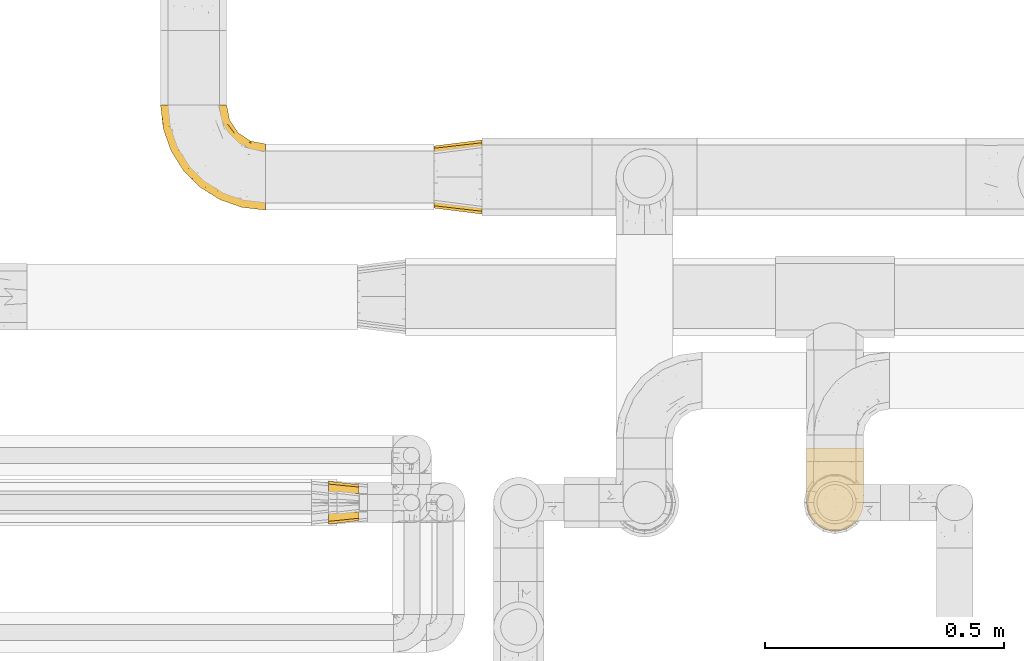
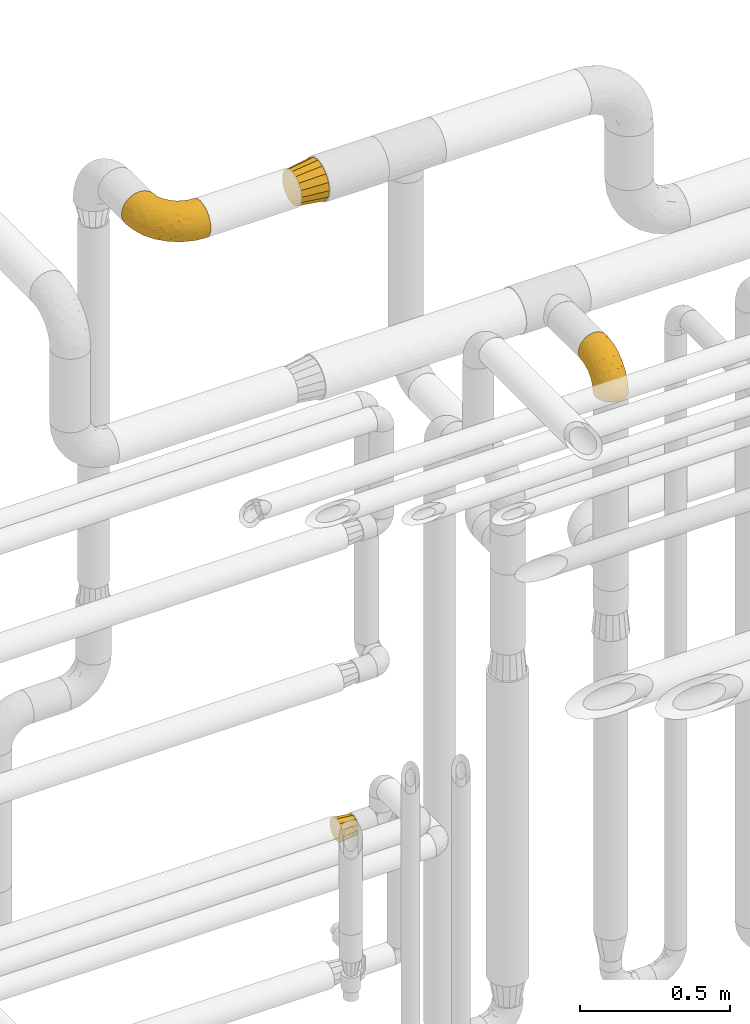
# One storey, part 459 of 827: 4 coverings.
"""IFC2X3 building model written with IfcOpenShell, lengths in millimetres."""

from ifc_helpers import new_model, entity, si_unit, converted_unit, derived_unit, direction, frame, origin, place, context, subcontext, project, spatial, faceted_brep, element, save


model = new_model("IFC2X3")

# Units and contexts
model_context = context("Model", 3, precision=0.01, world=origin(), true_north=direction((6.12303176911189e-17, 1.0)))
body_context = subcontext(model_context, "Body", "Model", "MODEL_VIEW")
ifc_project = project(units=[si_unit("LENGTHUNIT", "METRE", prefix="MILLI"), si_unit("AREAUNIT", "SQUARE_METRE"), si_unit("VOLUMEUNIT", "CUBIC_METRE"), converted_unit("PLANEANGLEUNIT", "DEGREE", entity("IfcRatioMeasure", 0.0174532925199433), si_unit("PLANEANGLEUNIT", "RADIAN"), dimensions=[0, 0, 0, 0, 0, 0, 0]), si_unit("MASSUNIT", "GRAM", prefix="KILO"), derived_unit("MASSDENSITYUNIT", [(si_unit("MASSUNIT", "GRAM", prefix="KILO"), 1), (si_unit("LENGTHUNIT", "METRE"), -3)]), derived_unit("MOMENTOFINERTIAUNIT", [(si_unit("LENGTHUNIT", "METRE"), 4)]), si_unit("TIMEUNIT", "SECOND"), si_unit("FREQUENCYUNIT", "HERTZ"), si_unit("THERMODYNAMICTEMPERATUREUNIT", "DEGREE_CELSIUS"), derived_unit("THERMALTRANSMITTANCEUNIT", [(si_unit("MASSUNIT", "GRAM", prefix="KILO"), 1), (si_unit("THERMODYNAMICTEMPERATUREUNIT", "KELVIN"), -1), (si_unit("TIMEUNIT", "SECOND"), -3)]), derived_unit("VOLUMETRICFLOWRATEUNIT", [(si_unit("LENGTHUNIT", "METRE"), 3), (si_unit("TIMEUNIT", "SECOND"), -1)]), derived_unit("MASSFLOWRATEUNIT", [(si_unit("MASSUNIT", "GRAM", prefix="KILO"), 1), (si_unit("TIMEUNIT", "SECOND"), -1)]), derived_unit("ROTATIONALFREQUENCYUNIT", [(si_unit("TIMEUNIT", "SECOND"), -1)]), si_unit("ELECTRICCURRENTUNIT", "AMPERE"), si_unit("ELECTRICVOLTAGEUNIT", "VOLT"), si_unit("POWERUNIT", "WATT"), si_unit("FORCEUNIT", "NEWTON", prefix="KILO"), si_unit("ILLUMINANCEUNIT", "LUX"), si_unit("LUMINOUSFLUXUNIT", "LUMEN"), si_unit("LUMINOUSINTENSITYUNIT", "CANDELA"), derived_unit("USERDEFINED", [(si_unit("MASSUNIT", "GRAM", prefix="KILO"), -1), (si_unit("LENGTHUNIT", "METRE"), -2), (si_unit("TIMEUNIT", "SECOND"), 3), (si_unit("LUMINOUSFLUXUNIT", "LUMEN"), 1)]), derived_unit("LINEARVELOCITYUNIT", [(si_unit("LENGTHUNIT", "METRE"), 1), (si_unit("TIMEUNIT", "SECOND"), -1)]), si_unit("PRESSUREUNIT", "PASCAL"), derived_unit("USERDEFINED", [(si_unit("LENGTHUNIT", "METRE"), -2), (si_unit("MASSUNIT", "GRAM", prefix="KILO"), 1), (si_unit("TIMEUNIT", "SECOND"), -2)]), derived_unit("LINEARFORCEUNIT", [(si_unit("MASSUNIT", "GRAM", prefix="KILO"), 1), (si_unit("LENGTHUNIT", "METRE"), 1), (si_unit("TIMEUNIT", "SECOND"), -2), (si_unit("LENGTHUNIT", "METRE"), -1)]), derived_unit("PLANARFORCEUNIT", [(si_unit("MASSUNIT", "GRAM", prefix="KILO"), 1), (si_unit("LENGTHUNIT", "METRE"), 1), (si_unit("TIMEUNIT", "SECOND"), -2), (si_unit("LENGTHUNIT", "METRE"), -2)])], contexts=[model_context])

# Site, building, storey
site_placement = place(None, origin())
site = spatial("IfcSite", under=ifc_project, at=site_placement, CompositionType="ELEMENT")
building_placement = place(site_placement, origin())
building = spatial("IfcBuilding", under=site, at=building_placement, CompositionType="ELEMENT")
storey_placement = place(building_placement, frame((0.0, 0.0, 28200.0)))
storey = spatial("IfcBuildingStorey", under=building, at=storey_placement, Name="08", CompositionType="ELEMENT", Elevation=28200.0)

# Coverings
covering_1_placement = place(storey_placement, frame((57386.84, 17438.95, 2784.4)))
element("IfcCovering", 1, at=covering_1_placement, inside=storey, Name=":ADSK_", ObjectType=":ADSK_", PredefinedType="INSULATION", context=body_context, shape_type="Brep", body=[
    faceted_brep([(119.0, 47.81, 1.6), (114.61, 35.25, 1.6), (107.52, 23.97, 1.6), (98.11, 14.56, 1.6), (86.83, 7.48, 1.6), (74.26, 3.08, 1.6), (61.05, 1.6, 1.6), (47.81, 3.09, 1.6), (35.25, 7.48, 1.6), (23.97, 14.57, 1.6), (14.56, 23.99, 1.6), (7.48, 35.26, 1.6), (3.08, 47.83, 1.6), (1.6, 61.05, 1.6), (3.09, 74.28, 1.6), (7.48, 86.84, 1.6), (14.57, 98.12, 1.6), (23.99, 107.53, 1.6), (35.26, 114.61, 1.6), (47.83, 119.01, 1.6), (61.05, 120.5, 1.6), (74.28, 119.0, 1.6), (86.84, 114.61, 1.6), (98.12, 107.52, 1.6), (107.53, 98.11, 1.6), (114.61, 86.83, 1.6), (119.01, 74.26, 1.6), (120.5, 61.05, 1.6), (45.66, 175.05, 58.17), (31.32, 175.05, 64.11), (19.01, 175.05, 73.56), (9.56, 175.05, 85.87), (3.62, 175.05, 100.21), (1.6, 175.05, 115.6), (3.62, 175.05, 130.98), (9.56, 175.05, 145.32), (19.01, 175.05, 157.63), (31.32, 175.05, 167.08), (45.66, 175.05, 173.02), (61.05, 175.05, 175.05), (76.43, 175.05, 173.02), (90.77, 175.05, 167.08), (103.08, 175.05, 157.63), (112.53, 175.05, 145.32), (118.47, 175.05, 130.98), (120.5, 175.05, 115.6), (118.47, 175.05, 100.21), (112.53, 175.05, 85.87), (103.08, 175.05, 73.56), (90.77, 175.05, 64.11), (76.43, 175.05, 58.17), (61.05, 175.05, 56.15), (95.74, 144.29, 160.93), (82.17, 133.4, 165.97), (93.88, 108.85, 151.16), (71.8, 137.58, 169.95), (61.05, 130.15, 169.14), (109.14, 33.43, 47.74), (108.65, 48.64, 81.62), (100.7, 32.13, 69.65), (79.94, 71.77, 137.09), (61.05, 88.32, 151.81), (61.05, 52.4, 124.24), (115.7, 105.93, 120.32), (112.92, 128.22, 136.76), (110.7, 102.42, 129.05), (117.93, 138.98, 127.83), (119.47, 114.96, 111.19), (89.21, 25.03, 73.49), (91.01, 14.44, 40.92), (83.0, 103.12, 154.8), (71.74, 109.71, 161.22), (106.1, 133.1, 148.51), (61.05, 7.51, 46.49), (79.17, 9.66, 43.55), (76.32, 38.78, 105.65), (73.8, 19.81, 75.81), (112.99, 73.56, 102.22), (104.29, 65.59, 111.05), (119.46, 53.66, 31.64), (119.47, 65.45, 61.68), (115.7, 56.32, 70.72), (120.5, 108.04, 93.82), (120.5, 123.93, 101.92), (120.5, 139.82, 110.02), (61.05, 24.83, 88.32), (115.97, 42.35, 34.61), (101.43, 20.84, 34.27), (94.14, 74.42, 130.32), (94.58, 46.21, 101.6), (104.07, 96.34, 135.16), (118.63, 83.99, 92.65), (120.5, 82.82, 68.6), (120.5, 95.43, 81.21), (120.5, 63.36, 16.21), (120.5, 66.62, 36.82), (120.5, 74.72, 52.71), (120.5, 160.43, 113.28), (117.67, 91.97, 49.51), (114.99, 88.98, 24.29), (109.18, 102.6, 33.37), (118.26, 155.55, 97.47), (117.87, 141.61, 92.13), (111.2, 123.71, 65.64), (103.41, 136.88, 63.0), (108.57, 141.73, 72.44), (112.76, 108.95, 54.52), (75.65, 132.33, 38.38), (89.98, 131.77, 46.09), (85.51, 122.46, 30.11), (61.05, 124.65, 22.47), (73.87, 123.29, 22.86), (111.26, 158.35, 82.06), (101.69, 153.2, 68.74), (88.74, 147.72, 56.57), (86.0, 162.85, 60.39), (74.52, 158.54, 55.21), (70.92, 144.02, 47.46), (61.05, 154.17, 51.99), (118.96, 76.05, 19.27), (119.01, 98.34, 66.98), (117.67, 113.97, 75.5), (82.93, 117.88, 15.03), (96.71, 111.71, 21.65), (96.25, 120.52, 38.96), (106.01, 101.36, 16.17), (119.26, 79.3, 36.61), (105.56, 112.64, 42.47), (61.05, 136.47, 40.17), (114.42, 138.23, 81.33), (119.14, 124.93, 89.72), (102.94, 123.97, 52.09), (18.7, 136.9, 62.98), (19.16, 123.98, 52.08), (10.9, 123.74, 65.65), (5.81, 148.89, 89.82), (2.95, 124.93, 89.72), (2.72, 138.07, 97.2), (46.46, 132.31, 38.35), (9.34, 108.96, 54.51), (1.6, 82.82, 68.6), (1.6, 95.43, 81.21), (3.08, 98.34, 66.99), (47.58, 158.54, 55.21), (7.11, 88.99, 24.29), (36.09, 162.86, 60.39), (16.09, 101.37, 16.17), (25.4, 111.72, 21.63), (3.83, 155.55, 97.47), (1.6, 160.43, 113.28), (4.42, 113.97, 75.5), (20.4, 153.21, 68.74), (51.15, 144.01, 47.46), (10.83, 158.35, 82.06), (16.53, 112.65, 42.47), (25.84, 120.51, 38.93), (48.24, 123.29, 22.84), (1.6, 66.62, 36.82), (1.6, 74.72, 52.71), (2.83, 79.32, 36.62), (1.6, 63.36, 16.21), (36.6, 122.45, 30.08), (39.17, 117.88, 15.02), (32.11, 131.76, 46.08), (33.35, 147.73, 56.57), (1.6, 123.93, 101.92), (4.42, 91.99, 49.52), (12.92, 102.61, 33.36), (3.14, 76.07, 19.28), (13.52, 141.72, 72.43), (1.6, 108.04, 93.82), (1.6, 139.82, 110.02), (7.67, 138.23, 81.33), (28.21, 108.85, 151.16), (26.35, 144.29, 160.93), (15.99, 133.1, 148.51), (9.17, 128.22, 136.76), (50.29, 137.58, 169.95), (39.92, 133.4, 165.97), (50.35, 109.71, 161.22), (2.62, 114.96, 111.19), (6.39, 56.32, 70.72), (2.63, 53.67, 31.66), (6.11, 42.36, 34.61), (17.8, 65.59, 111.05), (13.43, 48.62, 81.57), (27.5, 46.21, 101.58), (2.62, 65.45, 61.68), (3.46, 83.99, 92.65), (4.16, 138.98, 127.83), (39.09, 103.12, 154.8), (21.38, 32.14, 69.65), (20.65, 20.85, 34.27), (32.87, 25.03, 73.47), (31.06, 12.63, 32.52), (45.77, 38.78, 105.65), (42.15, 71.77, 137.09), (12.94, 33.44, 47.72), (11.39, 102.42, 129.05), (9.11, 73.52, 102.2), (42.91, 9.67, 43.54), (18.03, 96.34, 135.17), (27.95, 74.41, 130.32), (45.01, 20.85, 76.08), (6.39, 105.93, 120.32)], [[[0, 1, 2, 3, 4, 5, 6, 7, 8, 9, 10, 11, 12, 13, 14, 15, 16, 17, 18, 19, 20, 21, 22, 23, 24, 25, 26, 27]], [[28, 29, 30, 31, 32, 33, 34, 35, 36, 37, 38, 39, 40, 41, 42, 43, 44, 45, 46, 47, 48, 49, 50, 51]], [[52, 53, 54]], [[55, 39, 56]], [[57, 58, 59]], [[60, 61, 62]], [[63, 64, 65]], [[66, 63, 67]], [[59, 68, 69]], [[53, 70, 54]], [[41, 40, 53]], [[53, 71, 70]], [[72, 42, 52]], [[42, 41, 52]], [[73, 5, 74]], [[68, 75, 76]], [[43, 72, 64]], [[45, 44, 66]], [[58, 77, 78]], [[79, 80, 81]], [[67, 82, 83, 84]], [[75, 62, 85]], [[1, 0, 86]], [[2, 87, 3]], [[57, 87, 2]], [[42, 72, 43]], [[5, 4, 74]], [[2, 1, 57]], [[69, 3, 87]], [[5, 73, 6]], [[59, 87, 57]], [[66, 64, 63]], [[88, 89, 78]], [[54, 88, 90]], [[75, 60, 62]], [[91, 92, 93, 82]], [[79, 27, 94, 95]], [[76, 73, 74]], [[80, 95, 96, 92]], [[57, 1, 86]], [[56, 71, 55]], [[77, 91, 63]], [[80, 91, 81]], [[67, 91, 82]], [[71, 56, 61]], [[69, 4, 3]], [[74, 69, 68]], [[75, 89, 60]], [[80, 79, 95]], [[81, 57, 86]], [[76, 75, 85]], [[89, 68, 59]], [[58, 57, 81]], [[59, 58, 89]], [[90, 88, 78]], [[75, 68, 89]], [[70, 88, 54]], [[60, 89, 88]], [[77, 58, 81]], [[89, 58, 78]], [[91, 77, 81]], [[77, 63, 65]], [[78, 77, 65]], [[54, 90, 72]], [[91, 80, 92]], [[79, 81, 86]], [[86, 0, 79]], [[27, 79, 0]], [[66, 84, 97, 45]], [[91, 67, 63]], [[84, 66, 67]], [[64, 44, 43]], [[64, 66, 44]], [[65, 72, 90]], [[53, 52, 41]], [[72, 52, 54]], [[72, 65, 64]], [[65, 90, 78]], [[60, 71, 61]], [[55, 71, 53]], [[71, 60, 70]], [[88, 70, 60]], [[53, 40, 55]], [[39, 55, 40]], [[4, 69, 74]], [[59, 69, 87]], [[73, 76, 85]], [[68, 76, 74]], [[98, 99, 100]], [[84, 101, 97]], [[84, 83, 102]], [[97, 101, 46]], [[103, 104, 105]], [[47, 46, 101]], [[106, 98, 100]], [[107, 108, 109]], [[110, 107, 111]], [[112, 48, 47]], [[48, 113, 49]], [[113, 114, 115]], [[116, 51, 50]], [[115, 50, 49]], [[116, 117, 118]], [[119, 95, 94]], [[111, 107, 109]], [[93, 120, 121]], [[122, 123, 22]], [[121, 106, 103]], [[25, 24, 99]], [[114, 113, 104]], [[124, 109, 108]], [[25, 119, 26]], [[27, 26, 94]], [[112, 113, 48]], [[125, 123, 100]], [[24, 125, 99]], [[111, 20, 110]], [[109, 122, 111]], [[119, 94, 26]], [[99, 126, 119]], [[123, 124, 127]], [[117, 107, 128]], [[122, 22, 21]], [[129, 130, 121]], [[123, 23, 22]], [[92, 98, 120]], [[127, 106, 100]], [[23, 125, 24]], [[93, 121, 82]], [[119, 126, 95]], [[21, 20, 111]], [[123, 122, 109]], [[21, 111, 122]], [[107, 110, 128]], [[117, 128, 118]], [[107, 117, 108]], [[104, 108, 114]], [[124, 108, 131]], [[25, 99, 119]], [[96, 126, 98]], [[98, 92, 96]], [[123, 125, 23]], [[99, 125, 100]], [[103, 106, 131]], [[120, 106, 121]], [[83, 82, 130]], [[101, 102, 112]], [[130, 102, 83]], [[121, 130, 82]], [[102, 130, 129]], [[101, 112, 47]], [[112, 129, 105]], [[118, 51, 116]], [[108, 117, 114]], [[115, 116, 50]], [[114, 117, 116]], [[112, 102, 129]], [[102, 101, 84]], [[104, 103, 131]], [[129, 121, 103]], [[104, 131, 108]], [[105, 104, 113]], [[112, 105, 113]], [[103, 105, 129]], [[127, 124, 131]], [[123, 109, 124]], [[106, 127, 131]], [[123, 127, 100]], [[98, 126, 99]], [[95, 126, 96]], [[113, 115, 49]], [[116, 115, 114]], [[46, 45, 97]], [[92, 120, 93]], [[106, 120, 98]], [[132, 133, 134]], [[135, 136, 137]], [[110, 138, 128]], [[139, 134, 133]], [[140, 141, 142]], [[143, 51, 118]], [[16, 15, 144]], [[28, 145, 29]], [[146, 147, 17]], [[144, 146, 16]], [[31, 148, 32]], [[148, 149, 32]], [[139, 142, 150]], [[30, 29, 151]], [[152, 143, 118]], [[31, 30, 153]], [[139, 133, 154]], [[155, 154, 133]], [[110, 156, 138]], [[142, 141, 150]], [[20, 19, 156]], [[157, 158, 159]], [[14, 13, 160]], [[17, 16, 146]], [[161, 162, 147]], [[18, 162, 19]], [[152, 163, 164]], [[137, 136, 165]], [[144, 166, 167]], [[133, 163, 155]], [[144, 167, 146]], [[147, 18, 17]], [[29, 145, 151]], [[128, 138, 152]], [[160, 157, 168]], [[160, 168, 14]], [[14, 168, 15]], [[167, 166, 139]], [[151, 169, 153]], [[162, 156, 19]], [[141, 170, 150]], [[164, 163, 132]], [[147, 162, 18]], [[156, 162, 161]], [[156, 161, 138]], [[156, 110, 20]], [[163, 138, 161]], [[128, 152, 118]], [[155, 163, 161]], [[132, 163, 133]], [[159, 166, 144]], [[144, 15, 168]], [[166, 158, 140]], [[168, 159, 144]], [[147, 146, 167]], [[142, 139, 166]], [[134, 139, 150]], [[135, 31, 153]], [[136, 170, 165]], [[136, 150, 170]], [[148, 137, 171]], [[150, 136, 172]], [[151, 153, 30]], [[136, 135, 172]], [[163, 152, 138]], [[143, 28, 51]], [[152, 164, 143]], [[145, 143, 164]], [[171, 137, 165]], [[137, 148, 135]], [[31, 135, 148]], [[172, 135, 153]], [[150, 172, 134]], [[132, 169, 151]], [[169, 134, 172]], [[164, 132, 151]], [[134, 169, 132]], [[153, 169, 172]], [[161, 147, 155]], [[154, 147, 167]], [[147, 154, 155]], [[139, 154, 167]], [[157, 159, 168]], [[166, 159, 158]], [[143, 145, 28]], [[151, 145, 164]], [[149, 148, 171]], [[149, 33, 32]], [[140, 142, 166]], [[173, 174, 175]], [[35, 34, 176]], [[177, 178, 179]], [[180, 171, 165, 170]], [[181, 182, 183]], [[184, 185, 186]], [[187, 188, 140]], [[189, 33, 149, 171]], [[178, 190, 179]], [[34, 189, 176]], [[39, 38, 177]], [[191, 192, 193]], [[9, 8, 194]], [[174, 178, 37]], [[38, 37, 178]], [[35, 175, 36]], [[195, 62, 196]], [[180, 189, 171]], [[37, 36, 174]], [[183, 11, 197]], [[188, 170, 141, 140]], [[184, 198, 199]], [[8, 7, 200]], [[201, 184, 202]], [[13, 12, 182]], [[181, 185, 199]], [[183, 12, 11]], [[62, 195, 85]], [[202, 184, 186]], [[10, 197, 11]], [[199, 188, 181]], [[194, 8, 200]], [[203, 195, 193]], [[62, 61, 196]], [[197, 191, 185]], [[10, 192, 197]], [[7, 6, 73]], [[197, 192, 191]], [[192, 10, 9]], [[193, 192, 194]], [[7, 73, 200]], [[179, 61, 56]], [[203, 73, 85]], [[187, 140, 158, 157]], [[180, 188, 204]], [[179, 196, 61]], [[197, 181, 183]], [[181, 187, 182]], [[201, 173, 175]], [[203, 193, 200]], [[186, 191, 193]], [[197, 185, 181]], [[193, 195, 186]], [[196, 186, 195]], [[186, 196, 202]], [[190, 202, 196]], [[186, 185, 191]], [[199, 185, 184]], [[198, 184, 201]], [[188, 199, 204]], [[173, 201, 202]], [[175, 176, 198]], [[188, 180, 170]], [[189, 180, 204]], [[189, 204, 176]], [[189, 34, 33]], [[187, 157, 182]], [[188, 187, 181]], [[182, 157, 160, 13]], [[12, 183, 182]], [[198, 176, 204]], [[35, 176, 175]], [[175, 174, 36]], [[178, 174, 173]], [[199, 198, 204]], [[175, 198, 201]], [[177, 179, 56]], [[178, 173, 190]], [[202, 190, 173]], [[196, 179, 190]], [[39, 177, 56]], [[38, 178, 177]], [[193, 194, 200]], [[9, 194, 192]], [[73, 203, 200]], [[85, 195, 203]]]),
])
covering_2_placement = place(storey_placement, frame((56390.23, 17453.4, 1323.4)))
element("IfcCovering", 2, at=covering_2_placement, inside=storey, Name=":ADSK_", ObjectType=":ADSK_", PredefinedType="INSULATION", context=body_context, shape_type="Brep", body=[
    faceted_brep([(64.0, 9.1, 46.6), (64.0, 11.61, 37.22), (64.0, 14.12, 27.85), (64.0, 20.98, 20.98), (64.0, 27.85, 14.12), (64.0, 37.22, 11.61), (64.0, 46.6, 9.1), (64.0, 55.97, 11.61), (64.0, 65.35, 14.12), (64.0, 72.21, 20.98), (64.0, 79.07, 27.85), (64.0, 81.58, 37.22), (64.0, 84.1, 46.6), (64.0, 81.58, 55.97), (64.0, 79.07, 65.35), (64.0, 72.21, 72.21), (64.0, 65.35, 79.07), (64.0, 55.97, 81.58), (64.0, 46.6, 84.1), (64.0, 37.22, 81.58), (64.0, 27.85, 79.07), (64.0, 20.98, 72.21), (64.0, 14.12, 65.35), (64.0, 11.61, 55.97), (0.0, 77.33, 77.33), (0.0, 85.57, 69.1), (0.0, 88.1, 59.65), (0.0, 91.6, 46.6), (0.0, 88.1, 33.54), (0.0, 85.57, 24.1), (0.0, 77.33, 15.86), (0.0, 69.1, 7.62), (0.0, 59.65, 5.09), (0.0, 46.6, 1.6), (0.0, 33.54, 5.09), (0.0, 24.1, 7.62), (0.0, 15.86, 15.86), (0.0, 7.62, 24.1), (0.0, 5.09, 33.54), (0.0, 1.6, 46.6), (0.0, 5.09, 59.65), (0.0, 7.62, 69.1), (0.0, 15.86, 77.33), (0.0, 24.1, 85.57), (0.0, 33.54, 88.1), (0.0, 46.6, 91.6), (0.0, 59.65, 88.1), (0.0, 69.1, 85.57)], [[[0, 1, 2, 3, 4, 5, 6, 7, 8, 9, 10, 11, 12, 13, 14, 15, 16, 17, 18, 19, 20, 21, 22, 23]], [[24, 25, 26, 27, 28, 29, 30, 31, 32, 33, 34, 35, 36, 37, 38, 39, 40, 41, 42, 43, 44, 45, 46, 47]], [[4, 35, 34, 33, 6, 5]], [[37, 36, 35, 4, 3, 2]], [[1, 0, 39, 38, 37, 2]], [[10, 29, 28, 27, 12, 11]], [[31, 30, 29, 10, 9, 8]], [[7, 6, 33, 32, 31, 8]], [[16, 47, 46, 45, 18, 17]], [[25, 24, 47, 16, 15, 14]], [[13, 12, 27, 26, 25, 14]], [[22, 41, 40, 39, 0, 23]], [[43, 42, 41, 22, 21, 20]], [[19, 18, 45, 44, 43, 20]]]),
])
covering_3_placement = place(storey_placement, frame((56611.05, 18101.0, 3420.65)))
element("IfcCovering", 3, at=covering_3_placement, inside=storey, Name=":ADSK_", ObjectType=":ADSK_", PredefinedType="INSULATION", context=body_context, shape_type="Brep", body=[
    faceted_brep([(0.0, 144.1, 79.1), (0.0, 141.62, 66.66), (0.0, 139.15, 54.22), (0.0, 132.1, 43.68), (0.0, 125.06, 33.13), (0.0, 114.51, 26.09), (0.0, 103.97, 19.04), (0.0, 91.53, 16.57), (0.0, 79.1, 14.1), (0.0, 66.66, 16.57), (0.0, 54.22, 19.04), (0.0, 43.68, 26.09), (0.0, 33.13, 33.13), (0.0, 26.09, 43.68), (0.0, 19.04, 54.22), (0.0, 16.57, 66.66), (0.0, 14.1, 79.1), (0.0, 16.57, 91.53), (0.0, 19.04, 103.97), (0.0, 26.09, 114.51), (0.0, 33.13, 125.06), (0.0, 43.68, 132.1), (0.0, 54.22, 139.15), (0.0, 66.66, 141.62), (0.0, 79.1, 144.1), (0.0, 91.53, 141.62), (0.0, 103.97, 139.15), (0.0, 114.51, 132.1), (0.0, 125.06, 125.06), (0.0, 132.1, 114.51), (0.0, 139.15, 103.97), (0.0, 141.62, 91.53), (100.0, 7.49, 108.75), (100.0, 4.54, 93.92), (100.0, 1.6, 79.1), (100.0, 5.43, 59.82), (100.0, 7.49, 49.44), (100.0, 15.89, 36.87), (100.0, 24.29, 24.29), (100.0, 36.87, 15.89), (100.0, 49.44, 7.49), (100.0, 64.27, 4.54), (100.0, 79.1, 1.6), (100.0, 98.37, 5.43), (100.0, 108.75, 7.49), (100.0, 121.32, 15.89), (100.0, 133.9, 24.29), (100.0, 142.3, 36.87), (100.0, 150.7, 49.44), (100.0, 153.65, 64.27), (100.0, 156.6, 79.1), (100.0, 152.76, 98.37), (100.0, 150.7, 108.75), (100.0, 142.3, 121.32), (100.0, 133.9, 133.9), (100.0, 121.32, 142.3), (100.0, 108.75, 150.7), (100.0, 93.92, 153.65), (100.0, 79.1, 156.6), (100.0, 59.82, 152.76), (100.0, 49.44, 150.7), (100.0, 36.87, 142.3), (100.0, 24.29, 133.9), (100.0, 15.89, 121.32)], [[[0, 1, 2, 3, 4, 5, 6, 7, 8, 9, 10, 11, 12, 13, 14, 15, 16, 17, 18, 19, 20, 21, 22, 23, 24, 25, 26, 27, 28, 29, 30, 31]], [[32, 33, 34, 35, 36, 37, 38, 39, 40, 41, 42, 43, 44, 45, 46, 47, 48, 49, 50, 51, 52, 53, 54, 55, 56, 57, 58, 59, 60, 61, 62, 63]], [[6, 44, 43, 42, 8, 7]], [[45, 44, 6, 5, 4, 46]], [[4, 3, 2, 48, 47, 46]], [[0, 50, 49, 48, 2, 1]], [[14, 36, 35, 34, 16, 15]], [[37, 36, 14, 13, 12, 38]], [[12, 11, 10, 40, 39, 38]], [[8, 42, 41, 40, 10, 9]], [[22, 60, 59, 58, 24, 23]], [[61, 60, 22, 21, 20, 62]], [[20, 19, 18, 32, 63, 62]], [[16, 34, 33, 32, 18, 17]], [[30, 52, 51, 50, 0, 31]], [[53, 52, 30, 29, 28, 54]], [[28, 27, 26, 56, 55, 54]], [[24, 58, 57, 56, 26, 25]]]),
])
covering_4_placement = place(storey_placement, frame((56037.95, 18109.5, 3429.15)))
element("IfcCovering", 4, at=covering_4_placement, inside=storey, Name=":ADSK_", ObjectType=":ADSK_", PredefinedType="INSULATION", context=body_context, shape_type="Brep", body=[
    faceted_brep([(220.6, 44.18, 134.34), (220.6, 32.25, 127.96), (220.6, 21.8, 119.38), (220.6, 13.22, 108.92), (220.6, 6.84, 96.99), (220.6, 2.92, 84.05), (220.6, 1.6, 70.6), (220.6, 2.92, 57.13), (220.6, 6.85, 44.18), (220.6, 13.23, 32.25), (220.6, 21.81, 21.8), (220.6, 32.27, 13.22), (220.6, 44.2, 6.84), (220.6, 57.14, 2.92), (220.6, 70.6, 1.6), (220.6, 84.06, 2.92), (220.6, 97.01, 6.85), (220.6, 108.94, 13.23), (220.6, 119.39, 21.81), (220.6, 127.97, 32.27), (220.6, 134.35, 44.2), (220.6, 138.27, 57.14), (220.6, 139.6, 70.6), (220.6, 138.27, 84.06), (220.6, 134.34, 97.01), (220.6, 127.96, 108.94), (220.6, 119.38, 119.39), (220.6, 108.92, 127.97), (220.6, 96.99, 134.35), (220.6, 84.05, 138.27), (220.6, 70.6, 139.6), (220.6, 57.13, 138.27), (130.35, 220.6, 36.1), (119.39, 220.6, 21.8), (105.1, 220.6, 10.84), (88.45, 220.6, 3.95), (80.67, 220.6, 2.92), (70.6, 220.6, 1.6), (52.74, 220.6, 3.95), (36.1, 220.6, 10.84), (21.8, 220.6, 21.8), (10.84, 220.6, 36.1), (3.95, 220.6, 52.74), (1.6, 220.6, 70.6), (3.95, 220.6, 88.45), (10.84, 220.6, 105.1), (21.8, 220.6, 119.39), (36.1, 220.6, 130.35), (52.74, 220.6, 137.24), (70.6, 220.6, 139.6), (80.67, 220.6, 138.27), (88.45, 220.6, 137.24), (105.1, 220.6, 130.35), (119.39, 220.6, 119.39), (130.35, 220.6, 105.1), (137.24, 220.6, 88.45), (139.6, 220.6, 70.6), (137.24, 220.6, 52.74), (23.28, 125.57, 70.6), (17.64, 141.61, 83.48), (7.09, 171.86, 70.6), (6.91, 178.84, 83.77), (153.3, 72.46, 138.42), (187.95, 62.85, 138.7), (181.77, 75.71, 139.6), (13.73, 163.94, 95.16), (49.37, 84.05, 70.6), (84.05, 49.37, 70.6), (67.42, 67.42, 88.55), (163.19, 55.49, 134.98), (168.15, 41.48, 129.07), (43.66, 172.96, 131.06), (37.17, 152.88, 122.45), (58.2, 128.71, 129.1), (35.94, 105.17, 83.61), (90.42, 82.66, 127.05), (58.75, 110.03, 122.02), (84.04, 73.41, 117.32), (124.91, 58.01, 127.76), (19.44, 175.72, 110.77), (59.72, 89.2, 108.41), (38.75, 125.48, 111.97), (29.31, 191.27, 124.14), (90.59, 118.05, 137.81), (114.53, 114.53, 139.6), (102.61, 130.06, 139.6), (90.69, 145.6, 139.6), (136.35, 25.58, 99.97), (120.09, 41.09, 111.29), (94.71, 49.61, 100.2), (56.47, 180.8, 136.96), (148.93, 36.76, 120.82), (62.8, 143.84, 134.72), (72.92, 153.77, 138.53), (83.2, 163.68, 139.6), (75.71, 181.77, 139.6), (105.48, 36.22, 85.56), (138.66, 18.72, 83.03), (39.3, 108.58, 98.49), (186.81, 28.1, 122.52), (177.02, 20.51, 112.56), (172.0, 9.7, 89.27), (171.86, 7.09, 70.6), (172.65, 14.38, 101.45), (203.54, 72.84, 139.6), (109.58, 82.11, 133.88), (120.02, 93.43, 138.52), (163.68, 83.2, 139.6), (145.6, 90.69, 139.6), (79.61, 108.41, 132.65), (125.57, 23.28, 70.6), (130.06, 102.61, 139.6), (74.27, 192.66, 139.6), (72.84, 203.54, 139.6), (187.75, 142.03, 94.19), (199.25, 132.35, 106.02), (93.0, 192.52, 136.83), (188.21, 99.95, 134.87), (168.34, 116.93, 130.69), (165.08, 96.46, 138.16), (121.62, 150.71, 133.28), (127.61, 163.75, 126.08), (113.84, 170.88, 131.6), (190.42, 124.66, 118.74), (178.31, 135.88, 111.83), (160.84, 133.73, 123.27), (104.12, 155.7, 137.55), (101.41, 176.56, 135.67), (197.73, 112.66, 127.06), (147.57, 123.77, 133.33), (121.84, 133.08, 137.19), (140.06, 112.09, 137.97), (110.63, 197.78, 128.39), (140.98, 182.01, 101.84), (141.3, 196.55, 86.49), (135.18, 203.22, 99.1), (170.91, 148.02, 100.79), (152.06, 174.12, 86.27), (160.12, 147.99, 111.58), (145.76, 189.6, 70.6), (163.32, 163.32, 70.6), (126.29, 190.99, 116.89), (169.45, 155.31, 86.82), (189.6, 145.76, 70.6), (199.29, 86.59, 138.09), (138.92, 165.06, 116.82), (156.44, 161.33, 99.48), (137.84, 140.96, 129.97), (146.63, 147.95, 121.73), (120.65, 180.78, 125.02), (167.21, 154.28, 47.08), (153.88, 168.9, 49.2), (180.27, 114.34, 11.95), (193.45, 99.94, 6.82), (163.13, 102.81, 4.25), (144.97, 186.04, 53.51), (144.54, 174.36, 38.34), (135.94, 198.65, 41.46), (110.63, 197.78, 12.8), (126.84, 188.15, 23.89), (113.84, 170.88, 9.59), (153.87, 121.11, 8.56), (173.48, 130.33, 21.21), (150.81, 155.03, 27.96), (133.91, 160.46, 17.86), (136.92, 172.66, 27.1), (196.84, 139.19, 48.02), (183.06, 136.42, 32.97), (139.23, 202.91, 53.08), (165.54, 142.29, 27.99), (195.54, 123.93, 23.19), (202.93, 131.85, 35.67), (199.28, 86.6, 3.1), (93.0, 192.52, 4.37), (71.72, 212.07, 1.6), (75.71, 181.77, 1.6), (72.84, 203.54, 1.6), (95.03, 167.07, 2.93), (83.2, 163.68, 1.6), (108.27, 149.05, 3.68), (152.99, 138.43, 17.11), (128.64, 141.57, 7.87), (201.9, 112.64, 14.69), (178.55, 90.66, 2.91), (181.77, 75.71, 1.6), (203.54, 72.84, 1.6), (137.45, 112.26, 2.92), (145.6, 90.69, 1.6), (130.06, 102.61, 1.6), (114.53, 114.53, 1.6), (163.68, 83.2, 1.6), (121.81, 128.17, 3.18), (102.61, 130.06, 1.6), (90.69, 145.6, 1.6), (90.88, 118.5, 3.26), (117.93, 90.48, 3.41), (106.76, 84.57, 7.26), (137.57, 51.96, 12.98), (176.86, 40.41, 11.38), (148.92, 36.78, 20.36), (120.02, 41.14, 29.89), (177.02, 20.52, 28.62), (136.31, 25.6, 41.21), (61.37, 189.22, 2.7), (180.57, 56.17, 4.33), (94.7, 49.62, 41.0), (153.71, 72.69, 2.7), (15.6, 150.58, 52.64), (5.98, 183.31, 57.93), (9.04, 187.16, 45.26), (105.48, 36.22, 55.63), (20.73, 169.53, 30.68), (47.01, 173.26, 8.42), (186.8, 28.12, 18.66), (35.94, 105.17, 57.58), (39.3, 108.58, 42.7), (69.45, 150.31, 3.64), (18.31, 156.03, 41.02), (67.42, 67.42, 52.64), (64.57, 77.56, 39.64), (114.68, 53.96, 20.5), (143.56, 62.51, 6.62), (30.01, 185.29, 17.3), (40.58, 142.92, 19.21), (61.08, 139.61, 7.94), (64.86, 105.58, 17.12), (81.7, 109.18, 7.56), (137.37, 20.53, 52.86), (185.44, 11.92, 39.53), (171.98, 9.71, 51.91), (84.01, 73.45, 23.86), (50.73, 106.78, 28.24), (98.75, 77.17, 13.13), (31.7, 133.64, 33.14)], [[[0, 1, 2, 3, 4, 5, 6, 7, 8, 9, 10, 11, 12, 13, 14, 15, 16, 17, 18, 19, 20, 21, 22, 23, 24, 25, 26, 27, 28, 29, 30, 31]], [[32, 33, 34, 35, 36, 37, 38, 39, 40, 41, 42, 43, 44, 45, 46, 47, 48, 49, 50, 51, 52, 53, 54, 55, 56, 57]], [[58, 59, 60]], [[61, 43, 60]], [[62, 63, 64]], [[44, 65, 45]], [[66, 67, 68]], [[69, 70, 0]], [[71, 72, 73]], [[58, 74, 59]], [[75, 76, 77]], [[74, 58, 66]], [[77, 78, 75]], [[79, 46, 45]], [[80, 76, 81]], [[79, 45, 65]], [[47, 46, 82]], [[83, 84, 85, 86]], [[87, 88, 89]], [[49, 48, 90]], [[91, 70, 78]], [[90, 92, 93]], [[93, 86, 94, 95]], [[87, 96, 97]], [[74, 68, 98]], [[78, 70, 69]], [[70, 91, 99]], [[2, 99, 100]], [[4, 101, 5]], [[102, 101, 97]], [[81, 79, 65]], [[3, 100, 103]], [[68, 96, 89]], [[4, 3, 103]], [[59, 61, 60]], [[102, 6, 5]], [[86, 93, 83]], [[99, 2, 1]], [[68, 89, 80]], [[63, 69, 31]], [[63, 30, 104, 64]], [[92, 90, 71]], [[101, 103, 87]], [[69, 0, 31]], [[105, 62, 106]], [[62, 64, 107, 108]], [[88, 100, 91]], [[83, 106, 84]], [[3, 2, 100]], [[109, 83, 92]], [[96, 67, 110]], [[96, 68, 67]], [[106, 108, 111, 84]], [[102, 5, 101]], [[105, 69, 62]], [[90, 95, 112, 113, 49]], [[83, 93, 92]], [[97, 96, 110]], [[89, 96, 87]], [[95, 90, 93]], [[71, 48, 47]], [[48, 71, 90]], [[82, 71, 47]], [[81, 65, 98]], [[82, 79, 72]], [[1, 0, 70]], [[100, 99, 91]], [[70, 99, 1]], [[78, 69, 105]], [[75, 78, 105]], [[88, 78, 77]], [[87, 100, 88]], [[77, 76, 80]], [[78, 88, 91]], [[77, 89, 88]], [[68, 74, 66]], [[59, 98, 65]], [[105, 109, 75]], [[73, 76, 75]], [[75, 109, 73]], [[81, 76, 72]], [[79, 81, 72]], [[81, 98, 80]], [[83, 109, 105]], [[109, 92, 73]], [[68, 80, 98]], [[89, 77, 80]], [[98, 59, 74]], [[59, 65, 61]], [[65, 44, 61]], [[43, 61, 44]], [[71, 73, 92]], [[72, 76, 73]], [[69, 63, 62]], [[30, 63, 31]], [[105, 106, 83]], [[108, 106, 62]], [[79, 82, 46]], [[71, 82, 72]], [[4, 103, 101]], [[100, 87, 103]], [[102, 97, 110]], [[87, 97, 101]], [[24, 114, 115]], [[116, 112, 95]], [[116, 51, 112]], [[117, 118, 119]], [[52, 51, 116]], [[120, 121, 122]], [[123, 124, 125]], [[94, 126, 127]], [[117, 27, 128]], [[129, 130, 131]], [[124, 123, 115]], [[53, 52, 132]], [[133, 134, 135]], [[84, 131, 130]], [[114, 136, 124]], [[56, 55, 134]], [[134, 133, 137]], [[124, 136, 138]], [[139, 137, 140]], [[54, 53, 141]], [[123, 25, 115]], [[94, 86, 126]], [[26, 128, 27]], [[142, 143, 140]], [[117, 28, 27]], [[123, 26, 25]], [[132, 141, 53]], [[28, 144, 29]], [[144, 104, 29]], [[25, 24, 115]], [[133, 141, 145]], [[118, 128, 123]], [[143, 23, 22]], [[143, 114, 23]], [[141, 133, 135]], [[136, 142, 146]], [[119, 144, 117]], [[137, 142, 140]], [[23, 114, 24]], [[119, 131, 108]], [[118, 117, 128]], [[126, 85, 130]], [[28, 117, 144]], [[128, 26, 123]], [[107, 144, 119]], [[116, 127, 132]], [[107, 119, 108]], [[64, 144, 107]], [[131, 84, 111, 108]], [[119, 118, 131]], [[131, 118, 129]], [[125, 118, 123]], [[138, 146, 145]], [[147, 120, 130]], [[120, 126, 130]], [[114, 124, 115]], [[124, 138, 125]], [[148, 138, 145]], [[129, 125, 147]], [[116, 132, 52]], [[132, 122, 149]], [[121, 149, 122]], [[125, 148, 147]], [[134, 137, 139]], [[133, 145, 146]], [[146, 142, 137]], [[143, 142, 114]], [[133, 146, 137]], [[136, 146, 138]], [[56, 134, 139]], [[134, 55, 135]], [[55, 54, 135]], [[141, 135, 54]], [[104, 144, 64]], [[104, 30, 29]], [[142, 136, 114]], [[50, 49, 113, 112, 51]], [[116, 95, 94]], [[125, 129, 118]], [[130, 129, 147]], [[147, 148, 121]], [[126, 120, 122]], [[127, 126, 122]], [[138, 148, 125]], [[147, 121, 120]], [[149, 145, 141]], [[145, 149, 121]], [[132, 149, 141]], [[132, 127, 122]], [[94, 127, 116]], [[85, 126, 86]], [[85, 84, 130]], [[121, 148, 145]], [[140, 150, 151]], [[152, 153, 154]], [[155, 156, 157]], [[158, 159, 160]], [[152, 161, 162]], [[163, 164, 165]], [[166, 167, 150]], [[155, 168, 139]], [[167, 162, 169]], [[170, 167, 171]], [[15, 172, 16]], [[155, 151, 156]], [[34, 173, 35]], [[174, 37, 36, 35, 175, 176]], [[143, 21, 166]], [[34, 33, 158]], [[143, 150, 140]], [[173, 177, 178]], [[33, 32, 159]], [[166, 150, 143]], [[160, 179, 177]], [[143, 22, 21]], [[161, 180, 162]], [[179, 160, 181]], [[171, 166, 20]], [[32, 57, 157]], [[20, 166, 21]], [[17, 182, 18]], [[18, 170, 19]], [[153, 17, 16]], [[161, 152, 154]], [[183, 172, 184]], [[170, 162, 167]], [[153, 152, 182]], [[181, 164, 180]], [[180, 161, 181]], [[182, 170, 18]], [[184, 172, 185]], [[172, 15, 185]], [[157, 159, 32]], [[164, 163, 180]], [[186, 187, 188, 189]], [[20, 19, 171]], [[158, 173, 34]], [[183, 153, 172]], [[170, 171, 19]], [[166, 171, 167]], [[190, 187, 183, 184]], [[153, 16, 172]], [[183, 187, 154]], [[139, 168, 56]], [[157, 156, 165]], [[153, 182, 17]], [[170, 182, 152]], [[168, 155, 157]], [[140, 155, 139]], [[154, 186, 161]], [[160, 159, 164]], [[191, 161, 186]], [[191, 192, 179]], [[187, 186, 154]], [[191, 186, 189]], [[159, 158, 33]], [[173, 158, 160]], [[160, 164, 181]], [[165, 164, 159]], [[156, 150, 163]], [[169, 150, 167]], [[15, 14, 185]], [[152, 162, 170]], [[169, 180, 163]], [[180, 169, 162]], [[150, 169, 163]], [[154, 153, 183]], [[179, 181, 191]], [[177, 179, 193]], [[178, 175, 173]], [[160, 177, 173]], [[177, 193, 178]], [[161, 191, 181]], [[140, 151, 155]], [[150, 156, 151]], [[175, 35, 173]], [[157, 57, 168]], [[56, 168, 57]], [[157, 165, 159]], [[163, 165, 156]], [[192, 191, 189]], [[192, 193, 179]], [[194, 195, 196]], [[197, 198, 199]], [[200, 201, 202]], [[203, 37, 174, 176, 175]], [[198, 204, 12]], [[200, 202, 205]], [[206, 187, 190, 184]], [[189, 195, 194]], [[58, 60, 207]], [[10, 9, 201]], [[43, 42, 208]], [[209, 207, 208]], [[67, 210, 110]], [[211, 41, 40]], [[205, 202, 210]], [[203, 212, 38]], [[213, 198, 11]], [[214, 207, 215]], [[216, 175, 178, 193]], [[207, 209, 217]], [[218, 219, 205]], [[200, 220, 199]], [[195, 206, 221]], [[198, 221, 204]], [[210, 67, 218]], [[222, 40, 39]], [[14, 13, 204]], [[221, 206, 204]], [[198, 12, 11]], [[221, 197, 196]], [[66, 214, 218]], [[223, 224, 225]], [[203, 175, 216]], [[195, 189, 188, 187]], [[194, 226, 216]], [[213, 201, 199]], [[58, 214, 66]], [[67, 66, 218]], [[110, 210, 227]], [[213, 11, 10]], [[202, 201, 228]], [[7, 102, 229]], [[6, 102, 7]], [[230, 231, 225]], [[231, 219, 215]], [[7, 229, 8]], [[228, 8, 229]], [[38, 212, 39]], [[227, 102, 110]], [[225, 232, 230]], [[9, 8, 228]], [[40, 222, 211]], [[41, 209, 42]], [[223, 231, 233]], [[211, 217, 209]], [[205, 210, 218]], [[229, 227, 202]], [[226, 224, 216]], [[222, 212, 223]], [[201, 213, 10]], [[198, 213, 199]], [[219, 218, 215]], [[200, 199, 201]], [[205, 230, 200]], [[220, 200, 230]], [[207, 214, 58]], [[218, 214, 215]], [[233, 215, 217]], [[230, 205, 219]], [[225, 231, 223]], [[230, 219, 231]], [[224, 223, 212]], [[232, 225, 226]], [[196, 232, 226]], [[220, 197, 199]], [[230, 232, 220]], [[232, 196, 197]], [[232, 197, 220]], [[198, 197, 221]], [[212, 222, 39]], [[211, 222, 223]], [[187, 206, 195]], [[204, 184, 185, 14]], [[184, 204, 206]], [[204, 13, 12]], [[211, 209, 41]], [[208, 207, 60]], [[43, 208, 60]], [[42, 209, 208]], [[233, 217, 211]], [[215, 207, 217]], [[223, 233, 211]], [[215, 233, 231]], [[212, 203, 216]], [[37, 203, 38]], [[216, 193, 194]], [[194, 193, 192, 189]], [[202, 228, 229]], [[9, 228, 201]], [[227, 229, 102]], [[210, 202, 227]], [[225, 224, 226]], [[212, 216, 224]], [[194, 196, 226]], [[221, 196, 195]]]),
])

save(model, "model.ifc")
